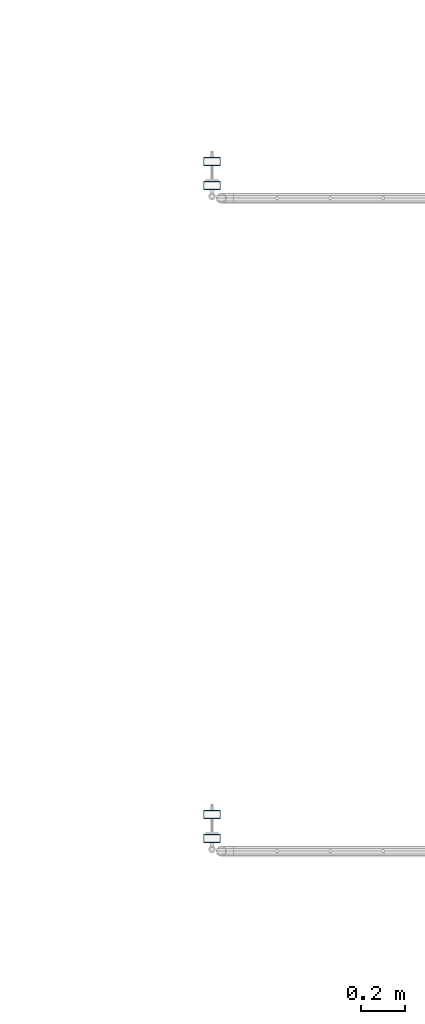
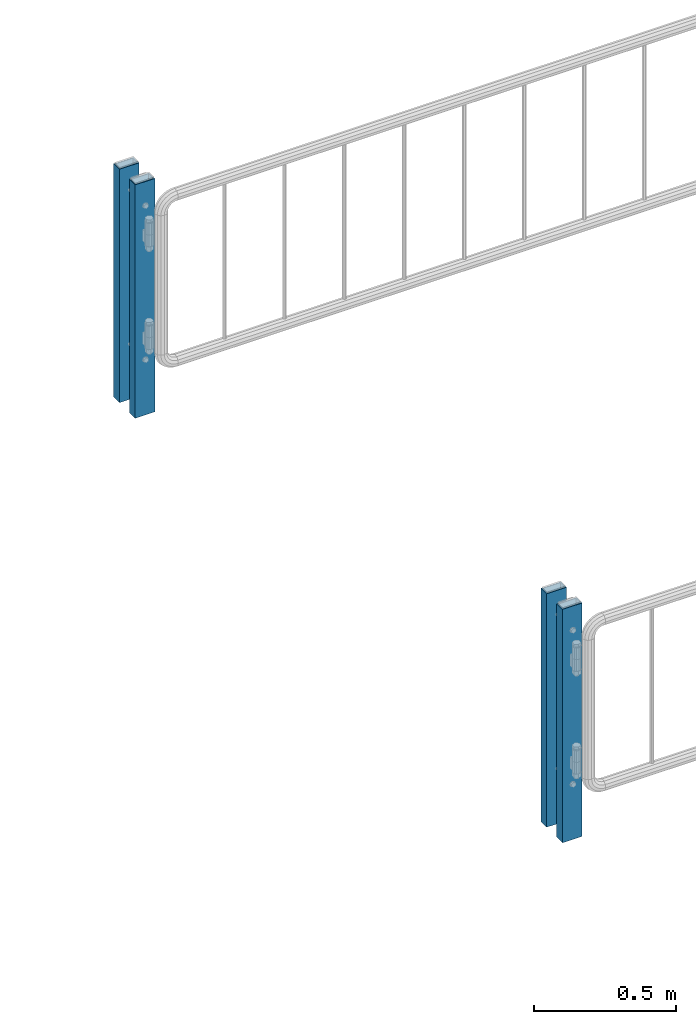
# One storey, part 62 of 219: 4 columns.
"""IFC2X3 building model written with IfcOpenShell, lengths in millimetres."""

from ifc_helpers import new_model, si_unit, frame, origin_with_axes, place, context, subcontext, project, spatial, faceted_brep, material, type_object, element, save


model = new_model("IFC2X3")

# Units and contexts
model_context = context("Model", 3, precision=1e-05, world=origin_with_axes())
body_context = subcontext(model_context, "Body", "Model", "MODEL_VIEW")
ifc_project = project(units=[si_unit("LENGTHUNIT", "METRE", prefix="MILLI"), si_unit("AREAUNIT", "SQUARE_METRE"), si_unit("VOLUMEUNIT", "CUBIC_METRE"), si_unit("MASSUNIT", "GRAM", prefix="KILO"), si_unit("TIMEUNIT", "SECOND"), si_unit("PLANEANGLEUNIT", "RADIAN"), si_unit("SOLIDANGLEUNIT", "STERADIAN"), si_unit("THERMODYNAMICTEMPERATUREUNIT", "DEGREE_CELSIUS"), si_unit("LUMINOUSINTENSITYUNIT", "LUMEN")], contexts=[model_context])

# Site, building, storey
site_placement = place(None, origin_with_axes())
site = spatial("IfcSite", under=ifc_project, at=site_placement, CompositionType="ELEMENT")
building_placement = place(site_placement, origin_with_axes())
building = spatial("IfcBuilding", under=site, at=building_placement, Name="Standard", CompositionType="ELEMENT")
storey_placement = place(building_placement, origin_with_axes())
storey = spatial("IfcBuildingStorey", under=building, at=storey_placement, Name="Undefined", CompositionType="ELEMENT", Elevation=0.0)

# Columns
ifc_material = material()
column_type = type_object("IfcColumnType", PredefinedType="NOTDEFINED")
for number, where, z_axis, x_axis in (
    (1, (24065.7460172356, 30110.3039999962, 6.54446186132418e-06), (-1.0, 0.0, 0.0), (0.0, 0.0, 1.0)),
    (2, (24065.7460172356, 30000.0039999962, 6.54446186132418e-06), (-1.0, 0.0, 0.0), (0.0, 0.0, 1.0)),
    (3, (24065.7460172356, 33110.3039999962, 6.54446186132418e-06), (-1.0, 0.0, 0.0), (0.0, 0.0, 1.0)),
    (4, (24065.7460172356, 33000.0039999962, 6.54446186132418e-06), (-1.0, 0.0, 0.0), (0.0, 0.0, 1.0)),
):
    element("IfcColumn", number, at=place(storey_placement, frame(where, z_axis=z_axis, x_axis=x_axis)), inside=storey, type_object=column_type, material=ifc_material, context=body_context, shape_type="Brep", body=[
        faceted_brep([(0.0, 16.0, -36.0), (0.0, -16.0, -36.0), (1000.0, -16.0, -36.0), (1000.0, 16.0, -36.0), (0.0, -16.0, 36.0), (1000.0, -16.0, 36.0), (0.0, 16.0, 36.0), (1000.0, 16.0, 36.0), (0.0, 20.0, -40.0), (0.0, 20.0, 40.0), (1000.0, 20.0, 40.0), (1000.0, 20.0, -40.0), (0.0, -20.0, 40.0), (1000.0, -20.0, 40.0), (0.0, -20.0, -40.0), (1000.0, -20.0, -40.0)], [[[0, 1, 2, 3]], [[1, 4, 5, 2]], [[4, 6, 7, 5]], [[6, 0, 3, 7]], [[8, 9, 10, 11]], [[9, 12, 13, 10]], [[12, 14, 15, 13]], [[14, 8, 11, 15]], [[13, 15, 11, 10], [5, 7, 3, 2]], [[14, 12, 9, 8], [6, 4, 1, 0]]]),
    ])

save(model, "model.ifc")
